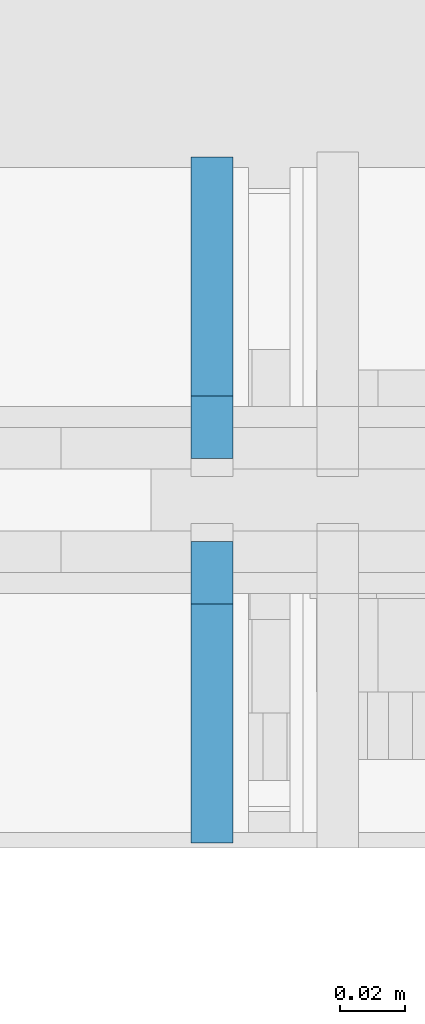
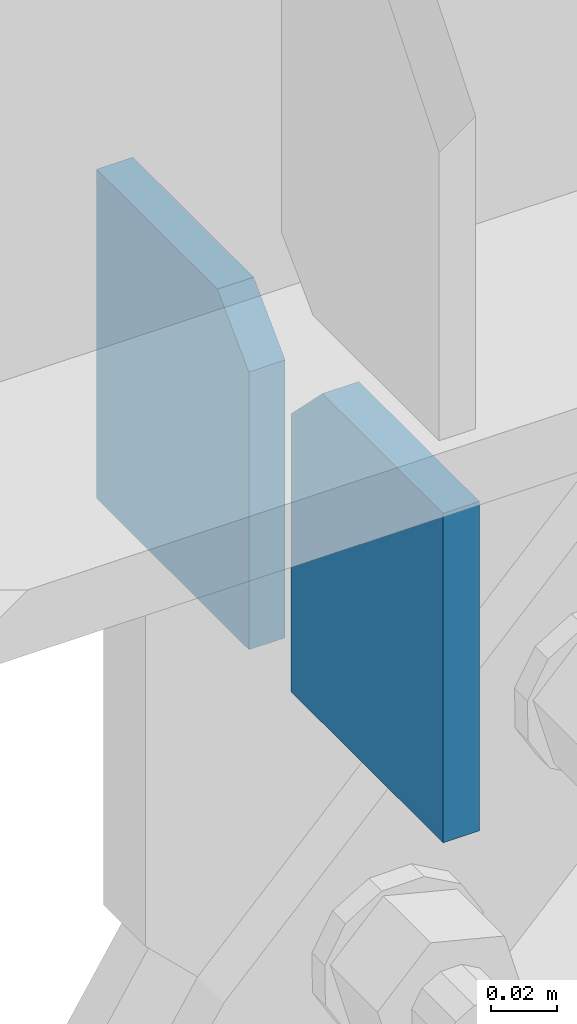
# One storey, part 519 of 1179: 2 columns, 1 element without a shape of its own.
"""IFC2X3 building model written with IfcOpenShell, lengths in millimetres."""

from ifc_helpers import new_model, si_unit, frame, origin_with_axes, place, context, subcontext, project, spatial, faceted_brep, material, type_object, element, aggregate, save


model = new_model("IFC2X3")

# Units and contexts
model_context = context("Model", 3, precision=1e-05, world=origin_with_axes())
body_context = subcontext(model_context, "Body", "Model", "MODEL_VIEW")
ifc_project = project(units=[si_unit("LENGTHUNIT", "METRE", prefix="MILLI"), si_unit("AREAUNIT", "SQUARE_METRE"), si_unit("VOLUMEUNIT", "CUBIC_METRE"), si_unit("MASSUNIT", "GRAM", prefix="KILO"), si_unit("TIMEUNIT", "SECOND"), si_unit("PLANEANGLEUNIT", "RADIAN"), si_unit("SOLIDANGLEUNIT", "STERADIAN"), si_unit("THERMODYNAMICTEMPERATUREUNIT", "DEGREE_CELSIUS"), si_unit("LUMINOUSINTENSITYUNIT", "LUMEN")], contexts=[model_context])

# Site, building, storey
site_placement = place(None, origin_with_axes())
site = spatial("IfcSite", under=ifc_project, at=site_placement, CompositionType="ELEMENT")
building_placement = place(site_placement, origin_with_axes())
building = spatial("IfcBuilding", under=site, at=building_placement, Name="Undefined", CompositionType="ELEMENT")
storey_placement = place(building_placement, origin_with_axes())
storey = spatial("IfcBuildingStorey", under=building, at=storey_placement, Name="Undefined", CompositionType="ELEMENT", Elevation=0.0)

# Assembly, columns
assembly_placement = place(storey_placement, origin_with_axes())
assembly = element("IfcElementAssembly", 1, at=assembly_placement, inside=storey, Name="BEAM", AssemblyPlace="NOTDEFINED", PredefinedType="RIGID_FRAME")
ifc_material = material(Name="STEEL/A572-GR.50")
column_type = type_object("IfcColumnType", PredefinedType="NOTDEFINED")
column_1_placement = place(assembly_placement, frame((3786.6294582368, 41257.5375, 3431.2629830839), z_axis=(0.0, -1.0, 0.0), x_axis=(0.0, 0.0, 1.0)))
column_1 = element("IfcColumn", 2, at=column_1_placement, type_object=column_type, material=ifc_material, Name="PLATE", context=body_context, shape_type="Brep", body=[
    faceted_brep([(102.512018829071, -6.35000000000036, 46.0374999999985), (121.562018829071, -6.35000000000036, 26.9875000000029), (121.562018829071, 6.35000000000036, 26.9875000000029), (102.512018829071, 6.35000000000036, 46.0374999999985), (121.562018829071, 6.35000000000036, -46.0374999999985), (0.0, 6.35000000000036, -46.0374999999985), (0.0, 6.35000000000036, 46.0374999999985), (0.0, -6.35000000000036, 46.0374999999985), (0.0, -6.35000000000036, -46.0374999999985), (121.562018829071, -6.35000000000036, -46.0374999999985)], [[[0, 1, 2, 3]], [[4, 5, 6, 3, 2]], [[6, 7, 0, 3]], [[7, 8, 9, 1, 0]], [[8, 5, 4, 9]], [[9, 4, 2, 1]], [[8, 7, 6, 5]]]),
])
column_2_placement = place(assembly_placement, frame((3786.6294582368, 41140.0625, 3431.2629830839), z_axis=(0.0, 1.0, 0.0), x_axis=(0.0, 0.0, 1.0)))
column_2 = element("IfcColumn", 3, at=column_2_placement, type_object=column_type, material=ifc_material, Name="PLATE", context=body_context, shape_type="Brep", body=[
    faceted_brep([(102.512018829071, -6.35000000000036, 46.0374999999985), (121.562018829071, -6.35000000000036, 26.9875000000029), (121.562018829071, 6.35000000000036, 26.9875000000029), (102.512018829071, 6.35000000000036, 46.0374999999985), (121.562018829071, 6.35000000000036, -46.0374999999985), (0.0, 6.35000000000036, -46.0374999999985), (0.0, 6.35000000000036, 46.0374999999985), (0.0, -6.35000000000036, 46.0374999999985), (0.0, -6.35000000000036, -46.0374999999985), (121.562018829071, -6.35000000000036, -46.0374999999985)], [[[0, 1, 2, 3]], [[4, 5, 6, 3, 2]], [[6, 7, 0, 3]], [[7, 8, 9, 1, 0]], [[8, 5, 4, 9]], [[9, 4, 2, 1]], [[8, 7, 6, 5]]]),
])
aggregate(assembly, [column_1, column_2])

save(model, "model.ifc")
